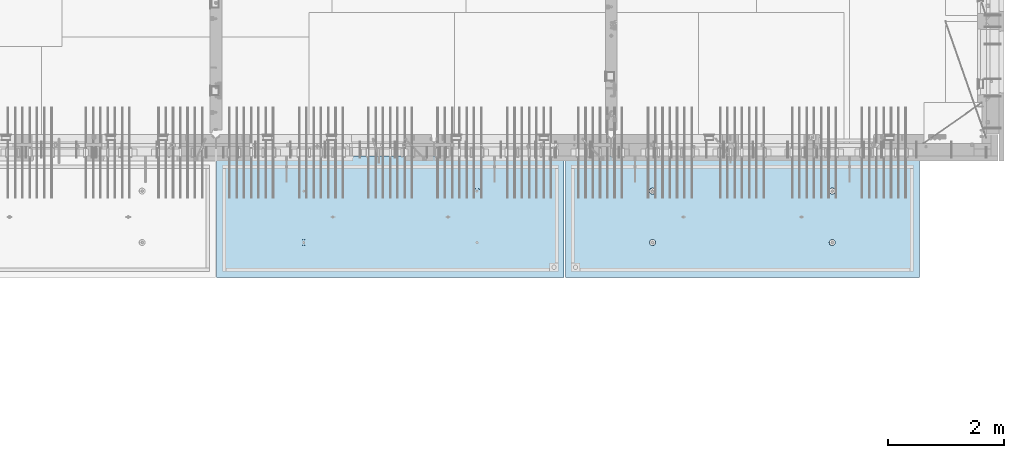
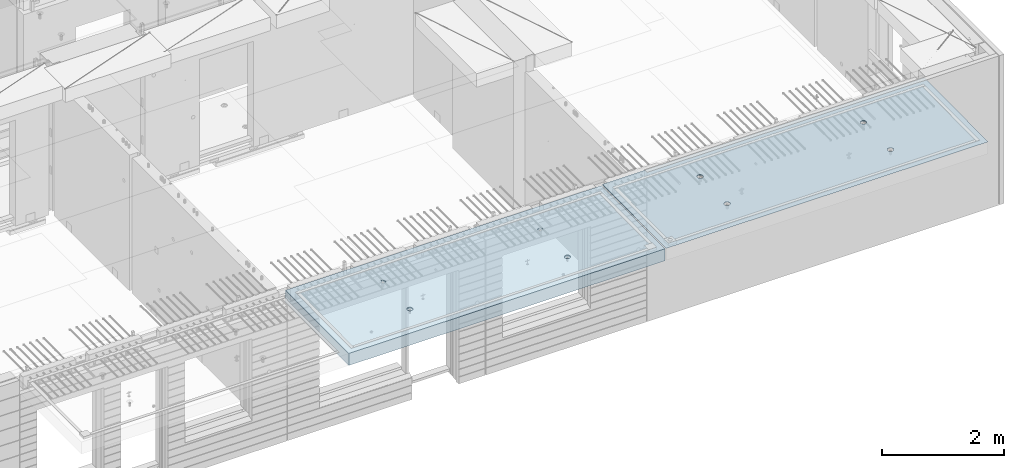
# One storey, part 201 of 352: 2 slabs, 2 elements without a shape of their own.
"""IFC2X3 building model written with IfcOpenShell, lengths in millimetres."""

import ifcopenshell
import ifcopenshell.guid

model = None  # the IFC model being written
_history = None  # IfcOwnerHistory: only IFC2X3 demands one
_inside = {}  # id of a spatial element -> (the spatial element, [elements in it])
_under = {}  # id of a project, library or spatial element -> (it, [spatial elements below it])
_declared = {}  # id of a project -> (the project, [libraries it declares])
_typed = {}  # id of a type object -> (the type object, [elements of that type])
_made_of = {}  # id of a material, layer set ... -> (it, [elements and type objects made of it])


def new_model(schema):
    """Start an empty IFC model of exactly this schema.

    Asked for "IFC4X3", IfcOpenShell would pick the latest addendum, in which some entities
    have other attributes; the version numbers below select the first issue.
    IFC2X3 requires an IfcOwnerHistory on every rooted entity: one is made here for all.
    """
    global model, _history
    if schema == "IFC4X3":
        model = ifcopenshell.file(schema_version=(4, 3, 0, 0))
    else:
        model = ifcopenshell.file(schema=schema)
    _inside.clear()
    _under.clear()
    _declared.clear()
    _typed.clear()
    _made_of.clear()
    _history = None
    if model.schema == "IFC2X3":
        org = make("IfcOrganization", Name="unknown")
        user = make(
            "IfcPersonAndOrganization",
            ThePerson=make("IfcPerson", FamilyName="unknown"),
            TheOrganization=org,
        )
        app = make(
            "IfcApplication",
            ApplicationDeveloper=org,
            Version="unknown",
            ApplicationFullName="unknown",
            ApplicationIdentifier="unknown",
        )
        _history = make(
            "IfcOwnerHistory",
            OwningUser=user,
            OwningApplication=app,
            ChangeAction="ADDED",
            CreationDate=0,
        )
    return model


def make(cls, **values):
    """One entity of the class cls with the attributes given. An attribute that is None is left unset."""
    return model.create_entity(
        cls, **{name: value for name, value in values.items() if value is not None}
    )


def rooted(cls, **values):
    """An entity with a GlobalId (a new one), such as an element, a storey or a relation."""
    return make(cls, GlobalId=ifcopenshell.guid.new(), OwnerHistory=_history, **values)


def si_unit(unit_type, name, prefix=None):
    """IfcSIUnit, for example si_unit("LENGTHUNIT", "METRE", prefix="MILLI")."""
    return make("IfcSIUnit", UnitType=unit_type, Prefix=prefix, Name=name)


def assignment(units):
    """IfcUnitAssignment: the units of a project."""
    return None if units is None else make("IfcUnitAssignment", Units=units)


def point(xyz):
    """IfcCartesianPoint."""
    return None if xyz is None else make("IfcCartesianPoint", Coordinates=xyz)


def direction(xyz):
    """IfcDirection."""
    return None if xyz is None else make("IfcDirection", DirectionRatios=xyz)


def frame(location, z_axis=None, x_axis=None):
    """IfcAxis2Placement3D, a coordinate frame: its origin and axes. An axis left out is left unset."""
    return make(
        "IfcAxis2Placement3D",
        Location=point(location),
        Axis=direction(z_axis),
        RefDirection=direction(x_axis),
    )


def origin_with_axes():
    """The frame at (0, 0, 0) with the z axis (0, 0, 1) and the x axis (1, 0, 0) written out."""
    return frame((0.0, 0.0, 0.0), z_axis=(0.0, 0.0, 1.0), x_axis=(1.0, 0.0, 0.0))


def place(relative_to, where):
    """IfcLocalPlacement: puts the frame where relative to a parent placement (None: the world)."""
    return make(
        "IfcLocalPlacement", PlacementRelTo=relative_to, RelativePlacement=where
    )


def context(
    kind, dimensions, precision=None, world=None, true_north=None, identifier=None
):
    """IfcGeometricRepresentationContext, for example the 3D "Model" context."""
    return make(
        "IfcGeometricRepresentationContext",
        ContextIdentifier=identifier,
        ContextType=kind,
        CoordinateSpaceDimension=dimensions,
        Precision=precision,
        WorldCoordinateSystem=world,
        TrueNorth=true_north,
    )


def subcontext(parent, identifier, kind, view, scale=None):
    """IfcGeometricRepresentationSubContext, for example "Body" below "Model"."""
    return make(
        "IfcGeometricRepresentationSubContext",
        ContextIdentifier=identifier,
        ContextType=kind,
        ParentContext=parent,
        TargetScale=scale,
        TargetView=view,
    )


def project(units=None, contexts=None):
    """IfcProject with its units and contexts."""
    return rooted(
        "IfcProject",
        Name="project",
        RepresentationContexts=contexts,
        UnitsInContext=assignment(units),
    )


def spatial(cls, under=None, at=None, **own):
    """A site, building, storey or space (cls), placed at a placement, below another one or the project."""
    s = rooted(cls, ObjectPlacement=at, **own)
    if under is not None:
        _under.setdefault(under.id(), (under, []))[1].append(s)
    return s


def faces_of(points, faces, orient=None, outer=None):
    """IfcFace entities. A face is a list of loops; a loop is a list of indices into points, from 0.

    orient and outer hold one flag for each loop. By default every Orientation is true, the
    first loop of a face is its IfcFaceOuterBound and the others are IfcFaceBound.
    """
    made = []
    for i, loops in enumerate(faces):
        bounds = []
        for j, loop in enumerate(loops):
            is_outer = j == 0 if outer is None else outer[i][j]
            bounds.append(
                make(
                    "IfcFaceOuterBound" if is_outer else "IfcFaceBound",
                    Bound=make("IfcPolyLoop", Polygon=[points[k] for k in loop]),
                    Orientation=True if orient is None else orient[i][j],
                )
            )
        made.append(make("IfcFace", Bounds=bounds))
    return made


def faceted_brep(points, faces, orient=None, outer=None, voids=None):
    """IfcFacetedBrep: a solid bounded by flat faces; with voids (closed shells), ...WithVoids."""
    shared = [point(p) for p in points]
    hull = make("IfcClosedShell", CfsFaces=faces_of(shared, faces, orient, outer))
    if voids is None:
        return make("IfcFacetedBrep", Outer=hull)
    return make(
        "IfcFacetedBrepWithVoids",
        Outer=hull,
        Voids=[
            make(cls, CfsFaces=faces_of(shared, fs, o, b)) for cls, fs, o, b in voids
        ],
    )


def shape(context_of_items, identifier, shape_type, items):
    """IfcShapeRepresentation: the items that make up one representation, for example the "Body"."""
    return make(
        "IfcShapeRepresentation",
        ContextOfItems=context_of_items,
        RepresentationIdentifier=identifier,
        RepresentationType=shape_type,
        Items=items,
    )


def material(Name=None, Category=None):
    """IfcMaterial."""
    return make("IfcMaterial", Name=Name, Category=Category)


def made_of(thing, what):
    """Note that an element or type object is made of a material, layer set ...; save() writes the relation."""
    if what is not None:
        _made_of.setdefault(what.id(), (what, []))[1].append(thing)
    return thing


def type_object(cls, material=None, **own):
    """A type object (cls), such as IfcWallType, which elements share."""
    return made_of(rooted(cls, **own), material)


def element(
    cls,
    number,
    at=None,
    inside=None,
    cuts=None,
    type_object=None,
    material=None,
    context=None,
    identifier="Body",
    shape_type=None,
    held_by="IfcProductDefinitionShape",
    body=None,
    shapes=None,
    **own,
):
    """One element of the class cls, such as IfcWall. Its Tag is "e" and its number.

    at: its placement. inside: the storey or other place that contains it. cuts: it is an
    opening in that element (IfcRelVoidsElement). A single representation is given by context,
    identifier, shape_type and body (its items); several are given by shapes. held_by: the class
    of the entity that holds the representations. save() writes the other relations.
    """
    e = rooted(cls, Tag="e%d" % number, ObjectPlacement=at, **own)
    if body is not None:
        shapes = [shape(context, identifier, shape_type, body)]
    if shapes is not None:
        e.Representation = make(held_by, Representations=shapes)
    if inside is not None:
        _inside.setdefault(inside.id(), (inside, []))[1].append(e)
    if cuts is not None:
        rooted(
            "IfcRelVoidsElement", RelatingBuildingElement=cuts, RelatedOpeningElement=e
        )
    if type_object is not None:
        _typed.setdefault(type_object.id(), (type_object, []))[1].append(e)
    return made_of(e, material)


def aggregate(whole, parts):
    """IfcRelAggregates: a whole, such as a stair, and the parts it consists of."""
    return rooted("IfcRelAggregates", RelatingObject=whole, RelatedObjects=parts)


def save(model, path):
    """Write the relations noted so far, then the file.

    IfcRelAggregates (storeys below a building ...), IfcRelContainedInSpatialStructure (elements
    in a storey), IfcRelDefinesByType, IfcRelAssociatesMaterial and IfcRelDeclares: one each for
    every whole, place, type object, material and project.
    """
    for whole, parts in _under.values():
        aggregate(whole, parts)
    for where, things in _inside.values():
        rooted(
            "IfcRelContainedInSpatialStructure",
            RelatedElements=things,
            RelatingStructure=where,
        )
    for kind, things in _typed.values():
        rooted("IfcRelDefinesByType", RelatedObjects=things, RelatingType=kind)
    for what, things in _made_of.values():
        rooted("IfcRelAssociatesMaterial", RelatedObjects=things, RelatingMaterial=what)
    for by, libraries in _declared.values():
        rooted("IfcRelDeclares", RelatingContext=by, RelatedDefinitions=libraries)
    model.write(path)


model = new_model("IFC2X3")

# Units and contexts
model_context = context("Model", 3, precision=1e-05, world=origin_with_axes())
body_context = subcontext(model_context, "Body", "Model", "MODEL_VIEW")
ifc_project = project(units=[si_unit("LENGTHUNIT", "METRE", prefix="MILLI"), si_unit("AREAUNIT", "SQUARE_METRE"), si_unit("VOLUMEUNIT", "CUBIC_METRE"), si_unit("MASSUNIT", "GRAM", prefix="KILO"), si_unit("TIMEUNIT", "SECOND"), si_unit("PLANEANGLEUNIT", "RADIAN"), si_unit("SOLIDANGLEUNIT", "STERADIAN"), si_unit("THERMODYNAMICTEMPERATUREUNIT", "DEGREE_CELSIUS"), si_unit("LUMINOUSINTENSITYUNIT", "LUMEN")], contexts=[model_context])

# Site, building, storey
site_placement = place(None, origin_with_axes())
site = spatial("IfcSite", under=ifc_project, at=site_placement, CompositionType="ELEMENT")
building_placement = place(site_placement, origin_with_axes())
building = spatial("IfcBuilding", under=site, at=building_placement, CompositionType="ELEMENT")
storey_placement = place(building_placement, origin_with_axes())
storey = spatial("IfcBuildingStorey", under=building, at=storey_placement, Name="6", CompositionType="ELEMENT", Elevation=0.0)

# Assembly, slab
assembly_1_placement = place(storey_placement, origin_with_axes())
assembly_1 = element("IfcElementAssembly", 1, at=assembly_1_placement, inside=storey, AssemblyPlace="NOTDEFINED", PredefinedType="REINFORCEMENT_UNIT")
ifc_material = material(Name="CONCRETE/C35/45")
slab_type_1 = type_object("IfcSlabType", PredefinedType="NOTDEFINED")
slab_1_placement = place(assembly_1_placement, frame((33909.9998568133, 7629.99655735226, 99720.0), z_axis=(-1.11800000013248e-06, -0.999999999999375, 0.0), x_axis=(-0.999999999999093, 1.34699999998405e-06, 0.0)))
slab_1 = element("IfcSlab", 2, at=slab_1_placement, type_object=slab_type_1, material=ifc_material, PredefinedType="FLOOR", context=body_context, shape_type="Brep", body=[
    faceted_brep([(4540.5429407651, 4.39872694581572, 1501.06992058926), (4541.14829635528, 10.0, 1500.87322939105), (4548.44394652849, 10.0, 1515.19178906455), (4547.94177529477, 4.5376880098047, 1515.55663695519), (4559.80720044041, 10.0, 1526.55506865745), (4559.44971344555, 4.64790814399021, 1527.04710612474), (4574.1257436257, 10.0, 1533.85075119058), (4573.94028523447, 4.71864591048507, 1534.42153123348), (4589.99797731422, 10.0, 1536.36468442559), (4589.99797663917, 4.74301553473924, 1536.96206902392), (4605.87021668419, 10.0, 1533.85078706184), (4606.05567377324, 4.71864625823218, 1534.42156748629), (4620.18877635769, 10.0, 1526.55513688863), (4620.54626219634, 4.64790880566579, 1527.04717510301), (4631.55205595059, 10.0, 1515.19188297671), (4632.05422627598, 4.53768892097287, 1515.5567319414), (4638.84773848372, 10.0, 1500.87333979142), (4639.45309351355, 4.39872801757883, 1501.0700323201), (4641.36167171873, 10.0, 1485.0011061029), (4642.01569559209, 4.24458991442225, 1485.00110684195), (4638.84777435497, 10.0, 1469.12886673293), (4639.48645790269, 4.09034788147255, 1468.92134666652), (4631.55212418177, 10.0, 1454.81030705943), (4632.10822132771, 3.95111487063696, 1454.40627979329), (4620.18887026985, 10.0, 1443.44702746653), (4620.60028327593, 3.84055859092041, 1442.88076738872), (4605.87032708456, 10.0, 1436.1513449334), (4606.0891136727, 3.76954887632746, 1435.47799164192), (4589.99809339604, 10.0, 1433.63741169839), (4589.99809419923, 3.74507537655882, 1432.92662480936), (4574.12585402606, 10.0, 1436.15130906214), (4573.90706894744, 3.76954852712515, 1435.47795523847), (4559.80729435257, 10.0, 1443.44695923535), (4559.39588258188, 3.84055792690197, 1442.8806981667), (4548.44401475967, 10.0, 1454.81021314727), (4547.88791844284, 3.95111395715503, 1454.40618456334), (4541.14833222653, 10.0, 1469.12875633256), (4540.50964903182, 4.09034680826881, 1468.92123478504), (4538.63439899152, 10.0, 1485.00099002108), (4537.98037499001, 4.24458878673613, 1485.00098928203), (0.0, 10.0, 0.0), (0.0, -10.0, 0.0), (0.000819232023786753, 10.0, 2085.00366210937), (6090.0, 10.0, 1.39971234602854e-09), (6090.0, -10.0, 1.39971234602854e-09), (6090.0009765625, 10.0, 2085.00366210937), (1450.13343574908, -4.39996016312216, 583.805178487186), (1451.68970517172, 10.0, 584.310843019489), (1449.20358093267, 10.0, 600.007498901724), (1447.58488291994, -4.2445425120095, 600.007497072595), (1457.56794425657, -4.54025428339082, 569.17949076172), (1458.90468325205, 10.0, 570.15069079864), (1469.16362510388, -4.65165300057561, 557.566154097598), (1470.14226284945, 10.0, 558.913136598135), (1483.78541952188, -4.72320365252381, 550.106985529351), (1484.30243137612, 10.0, 551.698190519764), (1499.99909477071, -4.74786334385863, 547.536208193364), (1499.99909287695, 10.0, 549.212101755165), (1516.2127641972, -4.72320330067305, 550.107022210277), (1515.69574875919, 10.0, 551.698225994214), (1530.8345417251, -4.65165233150765, 557.566223847243), (1529.85590098004, 10.0, 558.913204074546), (1542.4301962863, -4.54025336292398, 569.179586717545), (1541.09345518054, 10.0, 570.150783671952), (1549.86467170747, -4.39995908172568, 583.805291221456), (1548.30840125891, 10.0, 584.310952198615), (1552.41318790712, -4.24454137573775, 600.00761552858), (1550.79449002351, 10.0, 600.007613699451), (1549.83105300624, -4.08922839167644, 616.199022553535), (1548.30836578447, 10.0, 615.704269581685), (1542.37578967018, -3.94920829200419, 630.796143582923), (1541.09338770413, 10.0, 629.864421802535), (1530.78010888273, -3.83814828256436, 642.374169903326), (1529.85580810672, 10.0, 641.101976003039), (1516.17906941009, -3.76687165064504, 649.804771831361), (1515.69563958006, 10.0, 648.316922081409), (1499.99897631459, -3.74231662515376, 652.364637735232), (1499.99897807923, 10.0, 650.803010846011), (1483.81888899212, -3.76687200104061, 649.804735302227), (1484.30232219699, 10.0, 648.316886606961), (1469.21786628045, -3.83814894927491, 642.374100399286), (1470.14216997614, 10.0, 641.101908526629), (1457.62221161949, -3.94920921009907, 630.796047872702), (1458.90461577564, 10.0, 629.864328929222), (1450.16698124064, -4.08922947161773, 616.198909971055), (1451.68966969727, 10.0, 615.704160402559), (1450.509655854, 4.09040925785666, 1468.92774521603), (1451.1483322995, 10.0, 1469.13526457059), (1448.63439906449, 10.0, 1485.00749825911), (1447.98038215714, 4.24465121529647, 1485.00749752007), (1457.88792425878, 3.95117642574769, 1454.41269697389), (1458.44401483263, 10.0, 1454.8167213853), (1469.39588682837, 3.84062041057041, 1442.8872121491), (1469.80729442553, 10.0, 1443.45346747338), (1483.90707121489, 3.76961102048517, 1435.48447023045), (1484.12585409903, 10.0, 1436.15781730018), (1499.99809427218, 3.74513787325122, 1432.93314014929), (1499.998093469, 10.0, 1433.64391993642), (1516.08911155117, 3.76961136968748, 1435.48450663389), (1515.87032715752, 10.0, 1436.15785317143), (1530.60027917537, 3.8406210745743, 1442.88728137111), (1530.18887034281, 10.0, 1443.45353570456), (1542.1082156577, 3.95117733922962, 1454.41279220383), (1541.55212425473, 10.0, 1454.81681529746), (1549.48645122644, 4.09041033107496, 1468.92785709749), (1548.84777442794, 10.0, 1469.13537497096), (1552.0156885709, 4.24465234298259, 1485.00761507997), (1551.3616717917, 10.0, 1485.00761434093), (1549.45308684185, 4.39879042512621, 1501.07653836665), (1548.84773855669, 10.0, 1500.87984802946), (1542.05422061333, 4.5377513095591, 1515.56323601226), (1541.55205602355, 10.0, 1515.19839121474), (1530.54625810314, 4.64797117923445, 1527.0536776068), (1530.18877643065, 10.0, 1526.56164512666), (1516.05567165627, 4.71870862215292, 1534.42806898436), (1515.87021675715, 10.0, 1533.85729529987), (1499.99797671215, 4.74307789534214, 1536.96857017552), (1499.99797738718, 10.0, 1536.37119266363), (1483.94028749739, 4.71870827439125, 1534.42803273156), (1484.12574369866, 10.0, 1533.85725942862), (1469.44971768469, 4.64797051755886, 1527.05360862854), (1469.80720051337, 10.0, 1526.56157689548), (1457.94178110336, 4.53775039840548, 1515.56314102606), (1458.44394660145, 10.0, 1515.19829730258), (1450.54294758273, 4.39878935334855, 1501.07642663582), (1451.14829642825, 10.0, 1500.87973762909), (4619.85580803376, 10.0, 641.095467765007), (4620.78011297592, -3.83821065611846, 642.367667399533), (4606.17907152706, -3.76693401455123, 649.798270333285), (4605.6956395071, 10.0, 648.310413843377), (4631.09338763116, 10.0, 629.857913564502), (4632.37579533283, -3.94927068060497, 630.789639512066), (4638.30836571149, 10.0, 615.697761343654), (4639.83105967794, -4.08929079922382, 616.192516506986), (4640.79448995054, 10.0, 600.001105461418), (4642.4131949283, -4.24460380429809, 600.001107290555), (4638.30840118594, 10.0, 584.304443960583), (4639.86467838373, -4.40002153132809, 583.798780790478), (4631.09345510758, 10.0, 570.14427543392), (4632.43020195632, -4.54031583151664, 569.173074307006), (4619.85590090707, 10.0, 558.906695836514), (4620.83454582566, -4.65171481517609, 557.559709864858), (4605.69574868622, 10.0, 551.691717756181), (4606.21276631872, -4.72326579401852, 550.100507218302), (4589.99909280399, 10.0, 549.205593517132), (4589.99909469776, -4.74792584055103, 547.529692853434), (4574.30243130315, 10.0, 551.691682281732), (4573.78541725442, -4.72326614588383, 550.10047053737), (4560.14226277649, 10.0, 558.906628360102), (4559.16362085739, -4.65171548424405, 557.559640115202), (4548.90468317908, 10.0, 570.144182560607), (4547.56793844064, -4.54031675198348, 569.172978351166), (4541.68970509875, 10.0, 584.304334781456), (4540.1334289269, -4.40002261272457, 583.798668056191), (4547.6222058109, -3.9492715986853, 630.789543801832), (4559.21786204131, -3.83821132282901, 642.367597895483), (4573.8188867292, -3.76693436496134, 649.798233804147), (4589.99897624161, -3.74237898574211, 652.358136583629), (4537.58487575281, -4.2446049405844, 600.000988834554), (4540.166974423, -4.0892918791651, 616.192403924491), (4589.99897800626, 10.0, 650.796502607977), (4574.30232212402, 10.0, 648.310378368928), (4560.14216990317, 10.0, 641.095400288596), (4548.90461570267, 10.0, 629.85782069119), (4541.6896696243, 10.0, 615.697652164527), (4539.2035808597, 10.0, 600.000990663691)], [[[0, 1, 2, 3]], [[3, 2, 4, 5]], [[5, 4, 6, 7]], [[8, 9, 7, 6]], [[10, 11, 9, 8]], [[12, 13, 11, 10]], [[14, 15, 13, 12]], [[16, 17, 15, 14]], [[18, 19, 17, 16]], [[20, 21, 19, 18]], [[22, 23, 21, 20]], [[24, 25, 23, 22]], [[25, 24, 26, 27]], [[27, 26, 28, 29]], [[29, 28, 30, 31]], [[31, 30, 32, 33]], [[33, 32, 34, 35]], [[35, 34, 36, 37]], [[37, 36, 38, 39]], [[39, 38, 1, 0]], [[40, 41, 42]], [[40, 43, 44, 41]], [[43, 45, 44]], [[46, 47, 48, 49]], [[50, 51, 47, 46]], [[52, 53, 51, 50]], [[54, 55, 53, 52]], [[56, 57, 55, 54]], [[58, 59, 57, 56]], [[59, 58, 60, 61]], [[61, 60, 62, 63]], [[63, 62, 64, 65]], [[65, 64, 66, 67]], [[67, 66, 68, 69]], [[69, 68, 70, 71]], [[71, 70, 72, 73]], [[73, 72, 74, 75]], [[75, 74, 76, 77]], [[78, 79, 77, 76]], [[80, 81, 79, 78]], [[82, 83, 81, 80]], [[84, 85, 83, 82]], [[49, 48, 85, 84]], [[86, 87, 88, 89]], [[90, 91, 87, 86]], [[92, 93, 91, 90]], [[94, 95, 93, 92]], [[96, 97, 95, 94]], [[98, 99, 97, 96]], [[100, 101, 99, 98]], [[101, 100, 102, 103]], [[103, 102, 104, 105]], [[105, 104, 106, 107]], [[107, 106, 108, 109]], [[109, 108, 110, 111]], [[111, 110, 112, 113]], [[113, 112, 114, 115]], [[115, 114, 116, 117]], [[117, 116, 118, 119]], [[120, 121, 119, 118]], [[122, 123, 121, 120]], [[124, 125, 123, 122]], [[89, 88, 125, 124]], [[126, 127, 128, 129]], [[130, 131, 127, 126]], [[132, 133, 131, 130]], [[134, 135, 133, 132]], [[136, 137, 135, 134]], [[138, 139, 137, 136]], [[140, 141, 139, 138]], [[142, 143, 141, 140]], [[143, 142, 144, 145]], [[145, 144, 146, 147]], [[147, 146, 148, 149]], [[149, 148, 150, 151]], [[151, 150, 152, 153]], [[41, 44, 45, 42], [3, 5, 7, 9, 11, 13, 15, 17, 19, 21, 23, 25, 27, 29, 31, 33, 35, 37, 39, 0], [154, 155, 156, 157, 128, 127, 131, 133, 135, 137, 139, 141, 143, 145, 147, 149, 151, 153, 158, 159], [122, 120, 118, 116, 114, 112, 110, 108, 106, 104, 102, 100, 98, 96, 94, 92, 90, 86, 89, 124], [82, 80, 78, 76, 74, 72, 70, 68, 66, 64, 62, 60, 58, 56, 54, 52, 50, 46, 49, 84]], [[129, 128, 157, 160]], [[156, 161, 160, 157]], [[155, 162, 161, 156]], [[154, 163, 162, 155]], [[159, 164, 163, 154]], [[158, 165, 164, 159]], [[153, 152, 165, 158]], [[43, 40, 42, 45], [34, 32, 30, 28, 26, 24, 22, 20, 18, 16, 14, 12, 10, 8, 6, 4, 2, 1, 38, 36], [150, 148, 146, 144, 142, 140, 138, 136, 134, 132, 130, 126, 129, 160, 161, 162, 163, 164, 165, 152], [91, 93, 95, 97, 99, 101, 103, 105, 107, 109, 111, 113, 115, 117, 119, 121, 123, 125, 88, 87], [51, 53, 55, 57, 59, 61, 63, 65, 67, 69, 71, 73, 75, 77, 79, 81, 83, 85, 48, 47]]]),
])
aggregate(assembly_1, [slab_1])

assembly_2_placement = place(storey_placement, origin_with_axes())
assembly_2 = element("IfcElementAssembly", 3, at=assembly_2_placement, inside=storey, AssemblyPlace="NOTDEFINED", PredefinedType="REINFORCEMENT_UNIT")
slab_type_2 = type_object("IfcSlabType", PredefinedType="NOTDEFINED")
slab_2_placement = place(assembly_2_placement, frame((27799.9998568133, 7629.99655735226, 99590.0), z_axis=(-1.11800000013248e-06, -0.999999999999375, 0.0), x_axis=(-0.999999999999093, 1.34699999998405e-06, 0.0)))
slab_2 = element("IfcSlab", 4, at=slab_2_placement, type_object=slab_type_2, material=ifc_material, PredefinedType="FLOOR", context=body_context, shape_type="Brep", body=[
    faceted_brep([(4464.54840508898, -115.0, 647.555217913627), (4450.61000036748, -115.0, 640.453225774507), (4439.54842599525, -115.0, 629.391625938503), (4432.44646594236, -115.0, 615.453204868262), (4429.99930954105, -115.0, 600.002352332828), (4432.44650151022, -115.0, 584.551505430789), (4439.54849364933, -115.0, 570.613100709295), (4450.61009348534, -115.0, 559.551526337066), (4464.54851455558, -115.0, 552.449566284174), (4479.99936709102, -115.0, 550.002409882861), (4495.45021399306, -115.0, 552.449601852029), (4509.38861871455, -115.0, 559.551593991148), (4520.45019308678, -115.0, 570.613193827152), (4527.55215313967, -115.0, 584.551614897394), (4529.99930954098, -115.0, 600.002467432828), (4527.55211757181, -115.0, 615.453314334867), (4520.4501254327, -115.0, 629.39171905636), (4509.38852559669, -115.0, 640.453293428589), (4495.45010452645, -115.0, 647.555253481482), (4479.99925199102, -115.0, 650.002409882794), (4439.08882528693, -120.0, 570.279131286869), (4431.90612869169, -120.0, 584.375926971106), (4450.27612512107, -120.0, 559.091857205865), (4464.37293733984, -120.0, 551.909193061462), (4479.99936774499, -120.0, 549.43422806468), (4495.62579245274, -120.0, 551.909229033498), (4509.72258813697, -120.0, 559.091925628744), (4520.90986221798, -120.0, 570.279225462882), (4528.09252636238, -120.0, 584.37603768165), (4530.56749135916, -120.0, 600.002468086805), (4528.09249039035, -120.0, 615.628892794549), (4520.9097937951, -120.0, 629.725688478787), (4509.72249396096, -120.0, 640.912962559792), (4495.6256817422, -120.0, 648.095626704194), (4479.99925133704, -120.0, 650.570591700976), (4464.3728266293, -120.0, 648.095590732158), (4450.27603094506, -120.0, 640.912894136913), (4439.08875686405, -120.0, 629.725594302773), (4431.90609271965, -120.0, 615.628782084005), (4429.43112772287, -120.0, 600.002351678851), (0.000819232023786753, -120.0, 2085.00366210938), (5980.0009765625, -120.0, 2085.00366210937), (5980.0009765625, 120.0, 2085.00366210937), (0.000819232023786753, 120.0, 2085.00366210938), (5980.0, -120.0, -2.4019755073823e-09), (5980.0, 120.0, -2.4019755073823e-09), (-7.27595761418343e-12, -120.0, -9.09494701772928e-13), (-7.27595761418343e-12, 120.0, -9.09494701772928e-13), (1515.44890870648, -105.0, 1437.44477976918), (1529.38731342797, -105.0, 1444.5467719083), (1540.4488878002, -105.0, 1455.60837174431), (1547.55084785309, -105.0, 1469.54679281455), (1549.99800425441, -105.0, 1484.99764534998), (1547.55081228524, -105.0, 1500.44849225202), (1540.44882014612, -105.0, 1514.38689697351), (1529.38722031012, -105.0, 1525.44847134574), (1515.44879923988, -105.0, 1532.55043139864), (1499.99794670444, -105.0, 1534.99758779995), (1484.5470998024, -105.0, 1532.55039583078), (1470.60869508091, -105.0, 1525.44840369166), (1459.54712070868, -105.0, 1514.38680385566), (1452.44516065579, -105.0, 1500.44838278542), (1449.99800425447, -105.0, 1484.99753024998), (1452.44519622364, -105.0, 1469.54668334794), (1459.54718836276, -105.0, 1455.60827862645), (1470.60878819877, -105.0, 1444.54670425422), (1484.547209269, -105.0, 1437.44474420133), (1499.99806180444, -105.0, 1434.99758780001), (1450.82407776805, -120.0, 1469.01994796889), (1448.29345879993, -120.0, 1484.99752828805), (1458.16818327555, -120.0, 1454.60637035917), (1469.60688310596, -120.0, 1443.16769686061), (1484.02047762178, -120.0, 1435.82362453319), (1499.99806376637, -120.0, 1433.29304234547), (1515.97564408552, -120.0, 1435.82366131359), (1530.38922169525, -120.0, 1443.16776682109), (1541.82789519381, -120.0, 1454.6064666515), (1549.17196752123, -120.0, 1469.02006116732), (1551.70254970895, -120.0, 1484.99764731191), (1549.17193074083, -120.0, 1500.97522763107), (1541.82782523334, -120.0, 1515.38880524079), (1530.38912540293, -120.0, 1526.82747873935), (1515.9755308871, -120.0, 1534.17155106677), (1499.99794474251, -120.0, 1536.70213325449), (1484.02036442336, -120.0, 1534.17151428637), (1469.60678681363, -120.0, 1526.82740877888), (1458.16811331507, -120.0, 1515.38870894846), (1450.82404098765, -120.0, 1500.97511443265), (1484.54840517324, -115.0, 647.55178787166), (1470.61000045175, -115.0, 640.44979573254), (1459.54842607952, -115.0, 629.388195896537), (1452.44646602663, -115.0, 615.449774826296), (1449.99930962532, -115.0, 599.998922290862), (1452.44650159449, -115.0, 584.548075388822), (1459.5484937336, -115.0, 570.609670667329), (1470.61009356961, -115.0, 559.5480962951), (1484.54851463985, -115.0, 552.446136242207), (1499.99936717528, -115.0, 549.998979840894), (1515.45021407733, -115.0, 552.446171810063), (1529.38861879882, -115.0, 559.548163949182), (1540.45019317105, -115.0, 570.609763785185), (1547.55215322394, -115.0, 584.548184855427), (1549.99930962525, -115.0, 599.999037390861), (1547.55211765608, -115.0, 615.449884292901), (1540.45012551697, -115.0, 629.388289014393), (1529.38852568096, -115.0, 640.449863386622), (1515.45010461072, -115.0, 647.551823439516), (1499.99925207528, -115.0, 649.998979840828), (1451.90612877595, -120.0, 584.37249692914), (1449.43112780714, -120.0, 599.998921636884), (1459.0888253712, -120.0, 570.275701244902), (1470.27612520534, -120.0, 559.088427163899), (1484.3729374241, -120.0, 551.905763019496), (1499.99936782926, -120.0, 549.430798022713), (1515.62579253701, -120.0, 551.905798991532), (1529.72258822124, -120.0, 559.088495586778), (1540.90986230225, -120.0, 570.275795420916), (1548.09252644665, -120.0, 584.372607639683), (1550.56749144343, -120.0, 599.999038044839), (1548.09249047462, -120.0, 615.625462752582), (1540.90979387937, -120.0, 629.72225843682), (1529.72249404523, -120.0, 640.909532517825), (1515.62568182647, -120.0, 648.092196662227), (1499.9992514213, -120.0, 650.56716165901), (1484.37282671356, -120.0, 648.092160690191), (1470.27603102933, -120.0, 640.909464094946), (1459.08875694832, -120.0, 629.722164260806), (1451.90609280392, -120.0, 615.625352042039), (4495.44890862221, -105.0, 1437.44820981115), (4509.3873133437, -105.0, 1444.55020195027), (4520.44888771593, -105.0, 1455.61180178627), (4527.55084776882, -105.0, 1469.55022285651), (4529.99800417014, -105.0, 1485.00107539195), (4527.55081220097, -105.0, 1500.45192229399), (4520.44882006185, -105.0, 1514.39032701548), (4509.38722022585, -105.0, 1525.45190138771), (4495.44879915561, -105.0, 1532.5538614406), (4479.99794662017, -105.0, 1535.00101784192), (4464.54709971813, -105.0, 1532.55382587275), (4450.60869499664, -105.0, 1525.45183373363), (4439.54712062441, -105.0, 1514.39023389763), (4432.44516057152, -105.0, 1500.45181282738), (4429.9980041702, -105.0, 1485.00096029195), (4432.44519613937, -105.0, 1469.55011338991), (4439.54718827849, -105.0, 1455.61170866842), (4450.6087881145, -105.0, 1444.55013429619), (4464.54720918474, -105.0, 1437.44817424329), (4479.99806172017, -105.0, 1435.00101784198), (4430.82407768378, -120.0, 1469.02337801086), (4428.29345871566, -120.0, 1485.00095833002), (4438.16818319128, -120.0, 1454.60980040114), (4449.60688302169, -120.0, 1443.17112690258), (4464.02047753751, -120.0, 1435.82705457516), (4479.99806368211, -120.0, 1433.29647238744), (4495.97564400126, -120.0, 1435.82709135556), (4510.38922161098, -120.0, 1443.17119686305), (4521.82789510954, -120.0, 1454.60989669347), (4529.17196743696, -120.0, 1469.02349120928), (4531.70254962468, -120.0, 1485.00107735388), (4529.17193065656, -120.0, 1500.97865767303), (4521.82782514907, -120.0, 1515.39223528276), (4510.38912531866, -120.0, 1526.83090878132), (4495.97553080284, -120.0, 1534.17498110874), (4479.99794465824, -120.0, 1536.70556329646), (4464.02036433909, -120.0, 1534.17494432834), (4449.60678672936, -120.0, 1526.83083882084), (4438.1681132308, -120.0, 1515.39213899043), (4430.82404090338, -120.0, 1500.97854447461)], [[[0, 1, 2, 3, 4, 5, 6, 7, 8, 9, 10, 11, 12, 13, 14, 15, 16, 17, 18, 19]], [[20, 6, 5, 21]], [[22, 7, 6, 20]], [[23, 8, 7, 22]], [[24, 9, 8, 23]], [[25, 10, 9, 24]], [[26, 11, 10, 25]], [[27, 12, 11, 26]], [[28, 13, 12, 27]], [[29, 14, 13, 28]], [[30, 15, 14, 29]], [[31, 16, 15, 30]], [[32, 17, 16, 31]], [[33, 18, 17, 32]], [[34, 19, 18, 33]], [[35, 0, 19, 34]], [[36, 1, 0, 35]], [[37, 2, 1, 36]], [[38, 3, 2, 37]], [[39, 4, 3, 38]], [[21, 5, 4, 39]], [[40, 41, 42, 43]], [[41, 44, 45, 42]], [[44, 46, 47, 45]], [[42, 45, 47, 43]], [[46, 40, 43, 47]], [[48, 49, 50, 51, 52, 53, 54, 55, 56, 57, 58, 59, 60, 61, 62, 63, 64, 65, 66, 67]], [[68, 63, 62, 69]], [[70, 64, 63, 68]], [[71, 65, 64, 70]], [[72, 66, 65, 71]], [[73, 67, 66, 72]], [[74, 48, 67, 73]], [[75, 49, 48, 74]], [[76, 50, 49, 75]], [[77, 51, 50, 76]], [[78, 52, 51, 77]], [[79, 53, 52, 78]], [[80, 54, 53, 79]], [[81, 55, 54, 80]], [[82, 56, 55, 81]], [[83, 57, 56, 82]], [[84, 58, 57, 83]], [[85, 59, 58, 84]], [[86, 60, 59, 85]], [[87, 61, 60, 86]], [[69, 62, 61, 87]], [[88, 89, 90, 91, 92, 93, 94, 95, 96, 97, 98, 99, 100, 101, 102, 103, 104, 105, 106, 107]], [[108, 93, 92, 109]], [[110, 94, 93, 108]], [[111, 95, 94, 110]], [[112, 96, 95, 111]], [[113, 97, 96, 112]], [[114, 98, 97, 113]], [[115, 99, 98, 114]], [[116, 100, 99, 115]], [[117, 101, 100, 116]], [[118, 102, 101, 117]], [[119, 103, 102, 118]], [[120, 104, 103, 119]], [[121, 105, 104, 120]], [[122, 106, 105, 121]], [[123, 107, 106, 122]], [[124, 88, 107, 123]], [[125, 89, 88, 124]], [[126, 90, 89, 125]], [[127, 91, 90, 126]], [[109, 92, 91, 127]], [[128, 129, 130, 131, 132, 133, 134, 135, 136, 137, 138, 139, 140, 141, 142, 143, 144, 145, 146, 147]], [[148, 143, 142, 149]], [[150, 144, 143, 148]], [[151, 145, 144, 150]], [[152, 146, 145, 151]], [[153, 147, 146, 152]], [[154, 128, 147, 153]], [[155, 129, 128, 154]], [[156, 130, 129, 155]], [[157, 131, 130, 156]], [[158, 132, 131, 157]], [[159, 133, 132, 158]], [[160, 134, 133, 159]], [[161, 135, 134, 160]], [[162, 136, 135, 161]], [[163, 137, 136, 162]], [[164, 138, 137, 163]], [[165, 139, 138, 164]], [[166, 140, 139, 165]], [[167, 141, 140, 166]], [[149, 142, 141, 167]], [[44, 41, 40, 46], [37, 36, 35, 34, 33, 32, 31, 30, 29, 28, 27, 26, 25, 24, 23, 22, 20, 21, 39, 38], [166, 165, 164, 163, 162, 161, 160, 159, 158, 157, 156, 155, 154, 153, 152, 151, 150, 148, 149, 167], [126, 125, 124, 123, 122, 121, 120, 119, 118, 117, 116, 115, 114, 113, 112, 111, 110, 108, 109, 127], [86, 85, 84, 83, 82, 81, 80, 79, 78, 77, 76, 75, 74, 73, 72, 71, 70, 68, 69, 87]]]),
])
aggregate(assembly_2, [slab_2])

save(model, "model.ifc")
